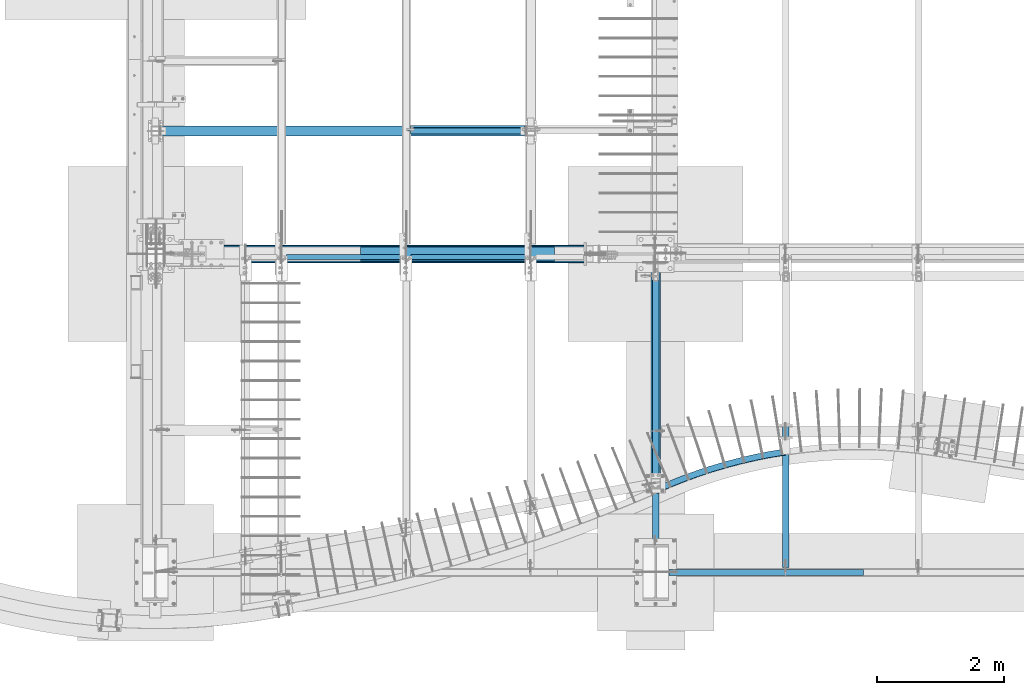
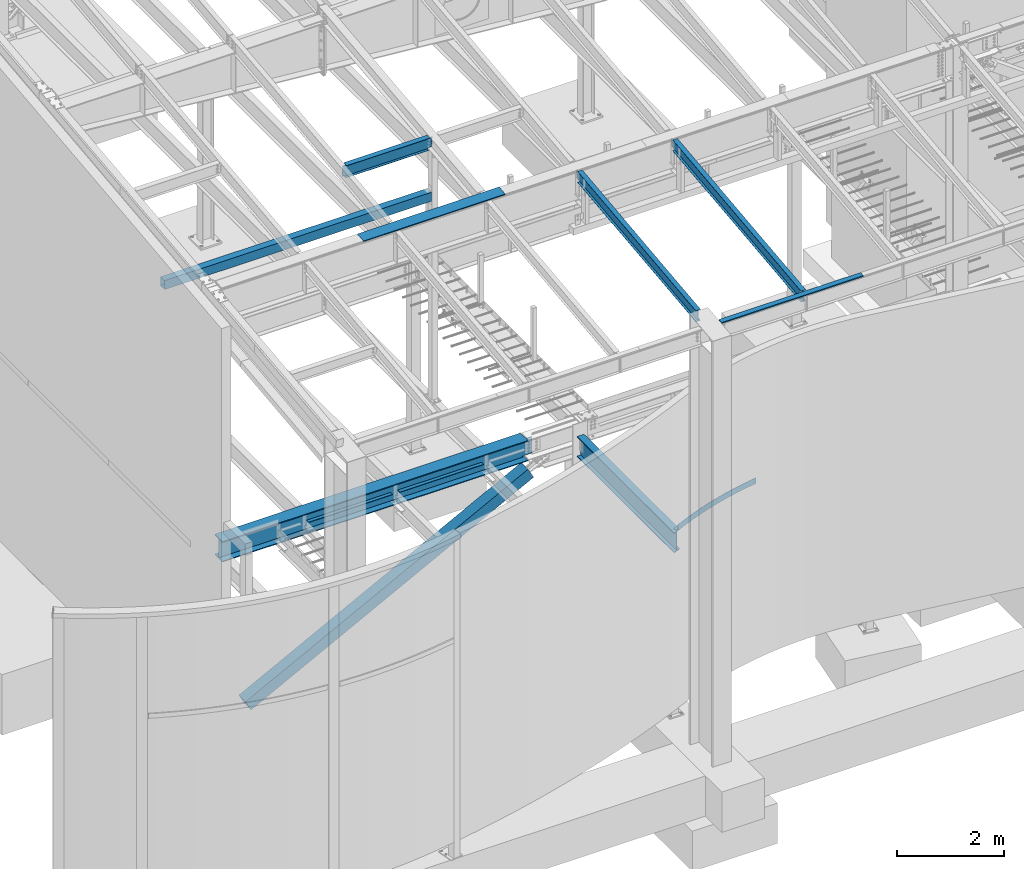
# One storey, part 705 of 1179: 11 beams, 1 member, 10 elements without a shape of their own.
"""IFC2X3 building model written with IfcOpenShell, lengths in millimetres."""

from ifc_helpers import new_model, si_unit, frame, origin_with_axes, place, context, subcontext, project, spatial, faceted_brep, material, type_object, element, aggregate, save


model = new_model("IFC2X3")

# Units and contexts
model_context = context("Model", 3, precision=1e-05, world=origin_with_axes())
body_context = subcontext(model_context, "Body", "Model", "MODEL_VIEW")
ifc_project = project(units=[si_unit("LENGTHUNIT", "METRE", prefix="MILLI"), si_unit("AREAUNIT", "SQUARE_METRE"), si_unit("VOLUMEUNIT", "CUBIC_METRE"), si_unit("MASSUNIT", "GRAM", prefix="KILO"), si_unit("TIMEUNIT", "SECOND"), si_unit("PLANEANGLEUNIT", "RADIAN"), si_unit("SOLIDANGLEUNIT", "STERADIAN"), si_unit("THERMODYNAMICTEMPERATUREUNIT", "DEGREE_CELSIUS"), si_unit("LUMINOUSINTENSITYUNIT", "LUMEN")], contexts=[model_context])

# Site, building, storey
site_placement = place(None, origin_with_axes())
site = spatial("IfcSite", under=ifc_project, at=site_placement, CompositionType="ELEMENT")
building_placement = place(site_placement, origin_with_axes())
building = spatial("IfcBuilding", under=site, at=building_placement, Name="Undefined", CompositionType="ELEMENT")
storey_placement = place(building_placement, origin_with_axes())
storey = spatial("IfcBuildingStorey", under=building, at=storey_placement, Name="Undefined", CompositionType="ELEMENT", Elevation=0.0)

# Assembly, beam
assembly_1_placement = place(storey_placement, origin_with_axes())
assembly_1 = element("IfcElementAssembly", 1, at=assembly_1_placement, inside=storey, Name="BEAM", AssemblyPlace="NOTDEFINED", PredefinedType="RIGID_FRAME")
ifc_material_1 = material(Name="STEEL/A992")
beam_type_1 = type_object("IfcBeamType", Name="W10X12", PredefinedType="NOTDEFINED")
beam_1_placement = place(assembly_1_placement, frame((10325.1, 452.231593993459, 9171.78056384809), z_axis=(-3.89779463887408e-08, -0.112282221021699, 0.993676357192035), x_axis=(0.0, 0.993676357192036, 0.112282221021699)))
beam_1 = element("IfcBeam", 2, at=beam_1_placement, type_object=beam_type_1, material=ifc_material_1, Name="BEAM", ObjectType="W10X12", context=body_context, shape_type="Brep", body=[
    faceted_brep([(4857.69134886906, 2.38125000000036, -120.649999999367), (4857.69134886908, 2.38119321150953, -125.412499999362), (4857.69133715173, 50.7999999999993, -125.412499999366), (4857.69133715173, 50.7999999999993, -120.649999999367), (4982.28709465017, 2.38125000000036, -120.649999999352), (4981.74894752234, 2.38122323349126, -125.412499999349), (48.8806597554974, -2.38124999999854, -120.649999999914), (48.8806597554974, -50.7999999999993, -120.649999999914), (4857.69136171279, -50.7999999999993, -120.649999999368), (4857.69134999544, -2.38125000000036, -120.649999999367), (76.1467808989316, 2.38124999999854, 120.649999999929), (76.1467808989316, 50.7999999999993, 120.649999999929), (4881.74500230402, 50.7999999999993, 120.650000000474), (4881.74500230402, 2.38125000000036, 120.650000000474), (48.3425126276663, -50.7999999999993, -125.412499999911), (76.1467808989316, -2.38124999999854, 120.649999999929), (76.1467808989316, -50.7999999999993, 120.649999999929), (76.6849280267622, -50.7999999999993, 125.412499999924), (76.6849280267622, 50.7999999999993, 125.412499999924), (48.8806597554974, 2.38124999999854, -120.649999999914), (48.8806597554974, 50.7999999999993, -120.649999999914), (48.3425126276663, 50.7999999999993, -125.412499999911), (4857.69136171279, -50.7999999999993, -125.412499999366), (4857.69134999547, -2.38130675233151, -125.412499999364), (4982.28709465017, -2.38125000000036, -120.649999999352), (4981.74894752234, -2.38127673034069, -125.412499999349), (4884.49824407442, -2.38125000000036, 75.1923220895023), (4880.7132366458, -2.38125000000036, 78.3905494782684), (4878.44025438672, -2.38125000000036, 82.793785937376), (4878.02533824148, -2.38125000000036, 87.7316786313622), (4881.74500230402, -2.38125000000036, 120.650000000474), (4982.37312427097, -2.38125000000036, -119.888654174249), (5002.79625141886, -2.38125000000036, 60.8521470148644), (4889.21904360274, -2.38125000000036, 73.6860048990093), (4881.74500230402, -50.7999999999993, 120.650000000474), (4882.28314943185, -50.7999999999993, 125.41250000047), (4882.28314943185, 50.7999999999993, 125.41250000047), (4878.02533824148, 2.38125000000036, 87.7316786313622), (4878.44025438672, 2.38125000000036, 82.793785937376), (4880.7132366458, 2.38125000000036, 78.3905494782684), (4884.49824407442, 2.38125000000036, 75.1923220895023), (4889.21904360274, 2.38125000000036, 73.6860048990093), (5002.79625141886, 2.38125000000036, 60.8521470148644), (4982.37311143735, 2.38125000000036, -119.888767749362)], [[[0, 1, 2, 3]], [[4, 5, 1, 0]], [[6, 7, 8, 9]], [[10, 11, 12, 13]], [[14, 7, 6, 15, 16, 17, 18, 11, 10, 19, 20, 21]], [[7, 14, 22, 8]], [[8, 22, 23, 9]], [[24, 9, 23, 25]], [[26, 27, 28, 29, 30, 15, 6, 9, 24, 31, 32, 33]], [[16, 15, 30, 34]], [[17, 16, 34, 35]], [[18, 17, 35, 36]], [[11, 18, 36, 12]], [[35, 34, 30, 29, 37, 13, 12, 36]], [[28, 38, 37, 29]], [[27, 39, 38, 28]], [[26, 40, 39, 27]], [[33, 41, 40, 26]], [[32, 42, 41, 33]], [[43, 4, 0, 19, 10, 13, 37, 38, 39, 40, 41, 42]], [[20, 19, 0, 3]], [[21, 20, 3, 2]], [[25, 23, 22, 14, 21, 2, 1, 5]], [[43, 42, 32, 31, 24, 25, 5, 4]]]),
])
aggregate(assembly_1, [beam_1])

assembly_2_placement = place(storey_placement, origin_with_axes())
assembly_2 = element("IfcElementAssembly", 3, at=assembly_2_placement, inside=storey, Name="BEAM", AssemblyPlace="NOTDEFINED", PredefinedType="RIGID_FRAME")
beam_2_placement = place(assembly_2_placement, frame((8280.4, 452.231593993459, 9171.78056384809), z_axis=(-3.89779463887408e-08, -0.112282221021699, 0.993676357192035), x_axis=(0.0, 0.993676357192036, 0.112282221021699)))
beam_2 = element("IfcBeam", 4, at=beam_2_placement, type_object=beam_type_1, material=ifc_material_1, Name="BEAM", ObjectType="W10X12", context=body_context, shape_type="Brep", body=[
    faceted_brep([(4857.69134886906, 2.38125000000036, -120.649999999367), (4857.69134886908, 2.38119321150953, -125.412499999362), (4857.69133715173, 50.7999999999993, -125.412499999366), (4857.69133715173, 50.7999999999993, -120.649999999367), (4982.28709465017, 2.38125000000036, -120.649999999352), (4981.74894752234, 2.38122323349126, -125.412499999349), (425.914889669142, -2.38124999999854, -120.64999999987), (425.914889669142, -50.7999999999993, -120.64999999987), (4857.69136171279, -50.7999999999993, -120.649999999368), (4857.69134999544, -2.38125000000036, -120.649999999367), (453.181010812576, 2.38124999999854, 120.649999999971), (453.181010812576, 50.7999999999993, 120.649999999971), (4881.74500230402, 50.7999999999993, 120.650000000474), (4881.74500230402, 2.38125000000036, 120.650000000474), (425.376742541311, -50.7999999999993, -125.412499999868), (453.181010812576, -2.38124999999854, 120.649999999971), (453.181010812576, -50.7999999999993, 120.649999999971), (453.719157940407, -50.7999999999993, 125.412499999969), (453.719157940407, 50.7999999999993, 125.412499999969), (449.277251936401, 2.38124999999854, 86.1024744511342), (431.940877010644, 2.38124999999854, -67.3211550991127), (425.914889669142, 2.38124999999854, -120.64999999987), (425.914889669142, 50.7999999999993, -120.64999999987), (425.376742541311, 50.7999999999993, -125.412499999868), (4857.69136171279, -50.7999999999993, -125.412499999366), (4857.69134999547, -2.38130675233151, -125.412499999364), (4982.28709465017, -2.38125000000036, -120.649999999352), (4981.74894752234, -2.38127673034069, -125.412499999349), (4884.49824407442, -2.38125000000036, 75.1923220895023), (4880.7132366458, -2.38125000000036, 78.3905494782684), (4878.44025438672, -2.38125000000036, 82.793785937376), (4878.02533824148, -2.38125000000036, 87.7316786313622), (4881.74500230402, -2.38125000000036, 120.650000000474), (4982.37312427097, -2.38125000000036, -119.888654174249), (5002.79625141886, -2.38125000000036, 60.8521470148644), (4889.21904360274, -2.38125000000036, 73.6860048990093), (4881.74500230402, -50.7999999999993, 120.650000000474), (4882.28314943185, -50.7999999999993, 125.41250000047), (4882.28314943185, 50.7999999999993, 125.41250000047), (4878.02533824148, 2.38125000000036, 87.7316786313622), (4878.44025438672, 2.38125000000036, 82.793785937376), (4880.7132366458, 2.38125000000036, 78.3905494782684), (4884.49824407442, 2.38125000000036, 75.1923220895023), (4889.21904360274, 2.38125000000036, 73.6860048990093), (5002.79625141886, 2.38125000000036, 60.8521470148644), (4982.37311143735, 2.38125000000036, -119.888767749362)], [[[0, 1, 2, 3]], [[4, 5, 1, 0]], [[6, 7, 8, 9]], [[10, 11, 12, 13]], [[14, 7, 6, 15, 16, 17, 18, 11, 10, 19, 20, 21, 22, 23]], [[7, 14, 24, 8]], [[8, 24, 25, 9]], [[26, 9, 25, 27]], [[28, 29, 30, 31, 32, 15, 6, 9, 26, 33, 34, 35]], [[16, 15, 32, 36]], [[17, 16, 36, 37]], [[18, 17, 37, 38]], [[11, 18, 38, 12]], [[37, 36, 32, 31, 39, 13, 12, 38]], [[30, 40, 39, 31]], [[29, 41, 40, 30]], [[28, 42, 41, 29]], [[35, 43, 42, 28]], [[34, 44, 43, 35]], [[45, 4, 0, 21, 20, 19, 10, 13, 39, 40, 41, 42, 43, 44]], [[22, 21, 0, 3]], [[23, 22, 3, 2]], [[27, 25, 24, 14, 23, 2, 1, 5]], [[45, 44, 34, 33, 26, 27, 5, 4]]]),
])
aggregate(assembly_2, [beam_2])

assembly_3_placement = place(storey_placement, origin_with_axes())
assembly_3 = element("IfcElementAssembly", 5, at=assembly_3_placement, inside=storey, Name="BEAM", AssemblyPlace="NOTDEFINED", PredefinedType="RIGID_FRAME")
beam_type_2 = type_object("IfcBeamType", Name="W12X14", PredefinedType="NOTDEFINED")
beam_3_placement = place(assembly_3_placement, frame((4368.8, 7382.95051456451, 9929.37147871498), z_axis=(0.0, -0.11280435903861, 0.993617218340085), x_axis=(1.0, 0.0, 0.0)))
beam_3 = element("IfcBeam", 6, at=beam_3_placement, type_object=beam_type_2, material=ifc_material_1, Name="BEAM", ObjectType="W12X14", context=body_context, shape_type="Brep", body=[
    faceted_brep([(15.0812499999993, -2.38124999998035, -131.762500001816), (15.0812499999993, 2.38125000001855, -131.762500001816), (53.1812501907352, 2.38125000001855, -131.762500001727), (53.1812501907352, -2.38124999998035, -131.76250000172), (58.0413297087807, 2.38125000001855, -132.729229924314), (58.0413297087807, -2.38124999997854, -132.729229924307), (62.1615061769344, 2.38125000001855, -135.482243824797), (62.1615061769344, -2.38124999997854, -135.482243824792), (64.9145200774128, 2.38125000001855, -139.602420292958), (64.9145200774128, -2.38124999997854, -139.602420292951), (65.8812500000004, 2.38125000002037, -144.462500000087), (65.8812500000004, -2.38124999997854, -144.462500000083), (65.8812500000004, -50.7999999999574, -144.462499810936), (65.8812500000004, 50.7999999999993, -144.46250000012), (65.8812500000004, 50.8000000000011, -150.812500000122), (65.8812500000004, -50.7999999999574, -150.812500000055), (1857.375, 50.7999999999593, 144.462500000054), (1857.375, 2.38124999997854, 144.462500000085), (65.8812500000004, 2.38124999997854, 144.462500000085), (65.8812500000004, 50.7999999999593, 144.462500000054), (53.1812501907352, -2.38125000001855, 131.762499998722), (53.1812501907352, 2.38124999998035, 131.762499998715), (15.0812499999993, 2.38124999998035, 131.762499998626), (15.0812499999993, -2.38125000001855, 131.762499998624), (58.0413297087807, -2.38125000001855, 132.729229921311), (58.0413297087807, 2.38124999998035, 132.729229921306), (62.1615061769344, -2.38125000001855, 135.482243821796), (62.1615061769344, 2.38124999998035, 135.482243821787), (64.9145200774128, -2.38125000001855, 139.602420289955), (64.9145200774128, 2.38124999998035, 139.60242028995), (65.8812500000004, -2.38125000001855, 144.462500000089), (1857.375, -50.7999999999993, 150.812500000124), (1857.375, 50.7999999999574, 150.812500000058), (65.8812500000004, 50.7999999999574, 150.812500000058), (65.8812500000004, -50.7999999999993, 150.812500000124), (1857.375, -50.7999999999993, 144.46250000012), (65.8812500000004, -50.7999999999993, 144.46250000012), (1857.375, -2.38125000001855, 144.462500000089), (1857.375, -2.38125000001855, 138.112499808019), (1857.375, 2.38124999998035, 138.11249980801), (1858.34172992259, -2.38125000001855, 133.252420289966), (1858.34172992259, 2.38124999998035, 133.252420289959), (1861.09474382307, -2.38125000001673, 129.132243821803), (1861.09474382307, 2.38124999998035, 129.132243821796), (1865.21492029122, -2.38125000001673, 126.379229921322), (1865.21492029122, 2.38124999998217, 126.379229921315), (1870.07499980927, -2.38125000001673, 125.412499998731), (1870.07499980927, 2.38124999998035, 125.412499998723), (1939.925, -2.38125000001673, 125.412499998822), (1939.925, 2.38124999998035, 125.412499998822), (1939.925, 2.38125000001673, -117.887500002969), (1939.925, 2.38124999998217, 112.712499998572), (1939.925, -2.38124999998035, -125.412500001634), (1939.925, 2.38125000001673, -125.412500001634), (1870.07499980927, -2.38124999998035, -125.412500001727), (1870.07499980927, 2.38125000001673, -125.412500001734), (1865.21492029122, -2.38124999998035, -126.379229924314), (1865.21492029122, 2.38125000001673, -126.379229924321), (1861.09474382307, -2.38124999998035, -129.132243824799), (1861.09474382307, 2.38125000001855, -129.132243824804), (1858.34172992259, -2.38124999998035, -133.252420292958), (1858.34172992259, 2.38125000001855, -133.252420292965), (1857.375, -2.38124999997854, -138.112499811014), (1857.375, 2.38125000001855, -138.112499811021), (1857.375, -2.38124999997854, -144.462500000083), (1857.375, -50.7999999999574, -144.462500000051), (1857.375, -50.7999999999574, -150.812500000055), (1857.375, 50.8000000000011, -150.812500000122), (1857.375, 50.7999999999993, -144.46250000012), (1857.375, 2.38125000002037, -144.462500000087), (15.0812499999993, 2.38125000001673, -117.887500002955), (15.0812499999993, 2.38124999998399, 112.712499998581)], [[[0, 1, 2, 3]], [[3, 2, 4, 5]], [[5, 4, 6, 7]], [[7, 6, 8, 9]], [[9, 8, 10, 11]], [[12, 11, 10, 13, 14, 15]], [[16, 17, 18, 19]], [[20, 21, 22, 23]], [[24, 25, 21, 20]], [[26, 27, 25, 24]], [[28, 29, 27, 26]], [[30, 18, 29, 28]], [[31, 32, 33, 34]], [[35, 31, 34, 36]], [[37, 35, 36, 30]], [[34, 33, 19, 18, 30, 36]], [[32, 16, 19, 33]], [[31, 35, 37, 38, 39, 17, 16, 32]], [[40, 41, 39, 38]], [[42, 43, 41, 40]], [[44, 45, 43, 42]], [[46, 47, 45, 44]], [[48, 49, 47, 46]], [[50, 51, 49, 48, 52, 53]], [[52, 54, 55, 53]], [[56, 57, 55, 54]], [[58, 59, 57, 56]], [[60, 61, 59, 58]], [[62, 63, 61, 60]], [[64, 65, 66, 67, 68, 69, 63, 62]], [[66, 65, 12, 15]], [[67, 66, 15, 14]], [[68, 67, 14, 13]], [[69, 68, 13, 10]], [[6, 4, 2, 1, 70, 71, 22, 21, 25, 27, 29, 18, 17, 39, 41, 43, 45, 47, 49, 51, 50, 53, 55, 57, 59, 61, 63, 69, 10, 8]], [[23, 22, 71, 70, 1, 0]], [[64, 62, 60, 58, 56, 54, 52, 48, 46, 44, 42, 40, 38, 37, 30, 28, 26, 24, 20, 23, 0, 3, 5, 7, 9, 11]], [[65, 64, 11, 12]]]),
])
aggregate(assembly_3, [beam_3])

assembly_4_placement = place(storey_placement, origin_with_axes())
assembly_4 = element("IfcElementAssembly", 7, at=assembly_4_placement, inside=storey, Name="BEAM", AssemblyPlace="NOTDEFINED", PredefinedType="RIGID_FRAME")
ifc_material_2 = material(Name="STEEL/A36")
beam_type_3 = type_object("IfcBeamType", PredefinedType="NOTDEFINED")
beam_4_placement = place(assembly_4_placement, frame((5172.07499932981, 5543.55933465712, 9826.91628422069), z_axis=(-1.0, 0.0, 0.0), x_axis=(0.0, 0.0, 1.0)))
beam_4 = element("IfcBeam", 8, at=beam_4_placement, type_object=beam_type_3, material=ifc_material_2, Name="BENT_PLATE", context=body_context, shape_type="Brep", body=[
    faceted_brep([(-2.91038304567337e-11, -4.76250000000073, -1524.0), (-2.91038304567337e-11, -4.76250000000073, 1524.0), (2.91038304567337e-11, 4.76250000000073, 1524.0), (2.91038304567337e-11, 4.76250000000073, -1524.0), (46.9151566473611, 4.76249999974698, 1524.0), (46.9151566473611, 4.76249999974698, -1524.0), (36.2535598523627, -4.76250000019536, -1524.0), (36.2535598523627, -4.76250000019536, 1524.0), (21.449529282756, -220.662499999238, 1524.0), (21.449529282756, -220.662499999238, -1524.0), (12.939957335464, -211.13749999934, -1524.0), (12.939957335464, -211.13749999934, 1524.0), (1.17463059723377e-07, -220.662499999494, 1524.0), (1.17463059723377e-07, -220.662499999494, -1524.0), (1.17350282380357e-07, -211.137499999494, 1524.0), (1.17350282380357e-07, -211.137499999494, -1524.0)], [[[0, 1, 2, 3]], [[3, 2, 4, 5]], [[1, 0, 6, 7]], [[5, 4, 8, 9]], [[7, 6, 10, 11]], [[9, 8, 12, 13]], [[8, 4, 2, 1, 7, 11, 14, 12]], [[11, 10, 15, 14]], [[10, 6, 0, 3, 5, 9, 13, 15]], [[14, 15, 13, 12]]]),
])
aggregate(assembly_4, [beam_4])

# Assembly, member
assembly_5_placement = place(storey_placement, origin_with_axes())
assembly_5 = element("IfcElementAssembly", 9, at=assembly_5_placement, inside=storey, Name="None", AssemblyPlace="NOTDEFINED", PredefinedType="RIGID_FRAME")
member_type = type_object("IfcMemberType", Name="HSS10X10X1/4", PredefinedType="NOTDEFINED")
member_placement = place(assembly_5_placement, frame((1166.68287804086, 5435.6, 166.554189613314), z_axis=(0.0, -1.0, 0.0), x_axis=(0.88706105467266, 0.0, 0.461652125829643)))
member = element("IfcMember", 10, at=member_placement, type_object=member_type, material=ifc_material_1, Name="None", ObjectType="HSS10X10X1/4", context=body_context, shape_type="Brep", body=[
    faceted_brep([(-6.09361450187862e-11, 120.650000000031, -120.650000000001), (6.00266503170133e-11, -120.650000000031, -120.650000000001), (6838.94999999862, -120.649999999846, -120.65), (6838.94999999861, 120.650000000161, -120.65), (6.00266503170133e-11, -120.650000000031, 120.650000000001), (6838.94999999862, -120.649999999846, 120.65), (-6.09361450187862e-11, 120.650000000031, 120.650000000001), (6838.94999999861, 120.650000000161, 120.65), (-6.3664629124105e-11, 127.000000000032, -127.0), (-6.3664629124105e-11, 127.000000000032, 127.0), (6838.94999999861, 127.000000000161, 127.0), (6838.94999999861, 127.000000000161, -127.0), (6.2755134422332e-11, -127.000000000033, 127.0), (6838.94999999862, -126.999999999846, 127.0), (6.2755134422332e-11, -127.000000000033, -127.0), (6838.94999999862, -126.999999999846, -127.0)], [[[0, 1, 2, 3]], [[1, 4, 5, 2]], [[4, 6, 7, 5]], [[6, 0, 3, 7]], [[8, 9, 10, 11]], [[9, 12, 13, 10]], [[12, 14, 15, 13]], [[14, 8, 11, 15]], [[13, 15, 11, 10], [5, 7, 3, 2]], [[14, 12, 9, 8], [6, 4, 1, 0]]]),
])
aggregate(assembly_5, [member])

# Assembly, beam
assembly_6_placement = place(storey_placement, origin_with_axes())
assembly_6 = element("IfcElementAssembly", 11, at=assembly_6_placement, inside=storey, Name="BEAM", AssemblyPlace="NOTDEFINED", PredefinedType="RIGID_FRAME")
beam_type_4 = type_object("IfcBeamType", PredefinedType="NOTDEFINED")
beam_5_placement = place(assembly_6_placement, frame((10017.1249999997, 485.774999119419, 9265.24531303941), z_axis=(-1.0, 0.0, 0.0), x_axis=(0.0, 0.0, 1.0)))
beam_5 = element("IfcBeam", 12, at=beam_5_placement, type_object=beam_type_4, material=ifc_material_2, Name="BENT_PLATE", context=body_context, shape_type="Brep", body=[
    faceted_brep([(0.0, -3.17499999999927, -1524.0), (6.00266503170133e-10, -3.17499999922438, 1524.00000000052), (6.00266503170133e-10, 3.17500000077416, 1524.00000000052), (0.0, 3.17499999999927, -1524.0), (36.8806648358295, 3.17499999974928, 1524.0), (36.8806648358295, 3.17499999974928, -1524.0), (29.7727112184712, -3.17500000020243, -1524.0), (29.7727112184712, -3.17500000020243, 1524.0), (25.3999996289767, -98.4249984738682, 1524.0), (25.3999996289767, -98.4249984738682, -1524.0), (19.7271291840298, -92.0749984738682, -1524.0), (19.7271291840298, -92.0749984738682, 1524.0), (2.13476596400142e-08, -98.4249984738682, 1524.0), (2.13476596400142e-08, -98.4249984738682, -1524.0), (2.13476596400142e-08, -92.0749984738682, 1524.0), (2.13476596400142e-08, -92.0749984738682, -1524.0)], [[[0, 1, 2, 3]], [[3, 2, 4, 5]], [[1, 0, 6, 7]], [[5, 4, 8, 9]], [[7, 6, 10, 11]], [[9, 8, 12, 13]], [[8, 4, 2, 1, 7, 11, 14, 12]], [[11, 10, 15, 14]], [[10, 6, 0, 3, 5, 9, 13, 15]], [[14, 15, 13, 12]]]),
])
aggregate(assembly_6, [beam_5])

# Assembly, beams
assembly_7_placement = place(storey_placement, origin_with_axes())
assembly_7 = element("IfcElementAssembly", 13, at=assembly_7_placement, inside=storey, Name="BEAM", AssemblyPlace="NOTDEFINED", PredefinedType="RIGID_FRAME")
beam_type_5 = type_object("IfcBeamType", PredefinedType="NOTDEFINED")
beam_6_placement = place(assembly_7_placement, frame((4445.0, 5391.15, 3844.131), z_axis=(0.0, 1.0, 0.0), x_axis=(1.0, 0.0, 0.0)))
beam_6 = element("IfcBeam", 14, at=beam_6_placement, type_object=beam_type_5, material=ifc_material_2, Name="PLATE", context=body_context, shape_type="Brep", body=[
    faceted_brep([(0.0, 3.96900000000005, -38.1000000000004), (0.0, 3.96900000000005, 38.1000000000004), (1803.4, 3.96900000000005, 38.1000000000004), (1803.4, 3.96900000000005, -38.1000000000004), (-3.63797880709171e-12, -3.96900000000005, 38.1000000000004), (1803.4, -3.96900000000005, 38.1000000000004), (-3.63797880709171e-12, -3.96900000000005, -38.1000000000004), (1803.4, -3.96900000000005, -38.1000000000004)], [[[0, 1, 2, 3]], [[1, 4, 5, 2]], [[4, 6, 7, 5]], [[6, 0, 3, 7]], [[5, 7, 3, 2]], [[6, 4, 1, 0]]]),
])
beam_7_placement = place(assembly_7_placement, frame((2489.2, 5391.15, 3844.131), z_axis=(0.0, 1.0, 0.0), x_axis=(1.0, 0.0, 0.0)))
beam_7 = element("IfcBeam", 15, at=beam_7_placement, type_object=beam_type_5, material=ifc_material_2, Name="PLATE", context=body_context, shape_type="Brep", body=[
    faceted_brep([(0.0, 3.96900000000005, -38.1000000000004), (0.0, 3.96900000000005, 38.1000000000004), (1803.4, 3.96900000000005, 38.1000000000004), (1803.4, 3.96900000000005, -38.1000000000004), (-3.63797880709171e-12, -3.96900000000005, 38.1000000000004), (1803.4, -3.96900000000005, 38.1000000000004), (-3.63797880709171e-12, -3.96900000000005, -38.1000000000004), (1803.4, -3.96900000000005, -38.1000000000004)], [[[0, 1, 2, 3]], [[1, 4, 5, 2]], [[4, 6, 7, 5]], [[6, 0, 3, 7]], [[5, 7, 3, 2]], [[6, 4, 1, 0]]]),
])

# Assembly, beam
assembly_8_placement = place(storey_placement, origin_with_axes())
assembly_8 = element("IfcElementAssembly", 16, at=assembly_8_placement, inside=storey, Name="BENT_PLATE", AssemblyPlace="NOTDEFINED", PredefinedType="RIGID_FRAME")
beam_type_6 = type_object("IfcBeamType", PredefinedType="NOTDEFINED")
beam_8_placement = place(assembly_8_placement, frame((10311.0905093915, 2327.25288585633, 3914.775), z_axis=(0.0, 0.0, 1.0), x_axis=(-0.976241347135425, -0.216686022030059, 0.0)))
beam_8 = element("IfcBeam", 17, at=beam_8_placement, type_object=beam_type_6, material=ifc_material_2, Name="BENT_PLATE", context=body_context, shape_type="Brep", body=[
    faceted_brep([(-7.09084831691143, -50.5522563652462, -66.6750000000002), (-7.09084831691143, -50.5522563652462, -60.3249999999998), (-0.443178031817297, 44.465483977162, -60.3249999999998), (-0.443178031817297, 44.465483977162, 66.6750000000002), (6.91215973347425e-11, 50.8000000000129, 66.6750000000002), (6.91215973347425e-11, 50.8000000000129, -66.6750000000002), (468.381702294399, -69.0111407792456, -60.3249999999998), (706.318555343563, -67.1632521933525, -60.3249999999998), (944.083390025935, -57.9304779824288, -60.3249999999998), (1181.4470556753, -41.3217164192761, -60.3249999999998), (1418.18078826021, -17.3529745336211, -60.3249999999998), (1654.05643085995, 13.9526473149756, -60.3249999999998), (1888.84665355536, 52.5649777005667, -60.3249999999998), (2122.32517252266, 98.4468032091336, -60.3249999999998), (2102.50994242848, 191.61288693229, -60.3249999999998), (1871.93293200984, 146.301248820536, -60.3249999999998), (1640.06051880417, 108.16876560544, -60.3249999999998), (1407.11617453738, 77.2521882386091, -60.3249999999998), (1173.32440403056, 53.5813131965078, -60.3249999999998), (938.910528829034, 37.1789537635007, -60.3249999999998), (704.100470044052, 28.0609180450924, -60.3249999999998), (469.12053061683, 26.2359937325405, -60.3249999999998), (234.197177214477, 31.7059396335453, -60.3249999999998), (230.502147330841, -63.4723628001266, -60.3249999999998), (234.197177214477, 31.7059396335453, 66.6750000000002), (469.12053061683, 26.2359937325405, 66.6750000000002), (704.100470044052, 28.0609180450924, 66.6750000000002), (938.910528829034, 37.1789537635007, 66.6750000000002), (1173.32440403056, 53.5813131965078, 66.6750000000002), (1407.11617453738, 77.2521882386091, 66.6750000000002), (1640.06051880417, 108.16876560544, 66.6750000000002), (1871.93293200984, 146.301248820536, 66.6750000000002), (2102.50994242848, 191.61288693229, 66.6750000000002), (2101.18892708886, 197.823959180501, 66.6750000000002), (1870.80535057347, 152.550333561868, 66.6750000000002), (1639.12745800046, 114.449840158138, 66.6750000000002), (1406.37853362252, 83.5591990900903, 66.6750000000002), (1172.78289392091, 59.9081818375587, 66.6750000000002), (938.565671415907, 43.5195825465617, 66.6750000000002), (703.95259769075, 34.4091960609881, 66.6750000000002), (469.169785838327, 32.5858026999936, 66.6750000000002), (234.443512540054, 38.0511597957907, 66.6750000000002), (234.443512540054, 38.0511597957907, -66.6750000000002), (469.169785838327, 32.5858026999936, -66.6750000000002), (703.95259769075, 34.4091960609881, -66.6750000000002), (938.565671415907, 43.5195825465617, -66.6750000000002), (1172.78289392091, 59.9081818375587, -66.6750000000002), (1406.37853362252, 83.5591990900903, -66.6750000000002), (1639.12745800046, 114.449840158138, -66.6750000000002), (1870.80535057347, 152.550333561868, -66.6750000000002), (2101.18892708886, 197.823959180501, -66.6750000000002), (2122.32517252266, 98.4468032091336, -66.6750000000002), (1888.84665355536, 52.5649777005667, -66.6750000000002), (1654.05643085995, 13.9526473149756, -66.6750000000002), (1418.18078826021, -17.3529745336211, -66.6750000000002), (1181.4470556753, -41.3217164192761, -66.6750000000002), (944.083390025935, -57.9304779824288, -66.6750000000002), (706.318555343563, -67.1632521933525, -66.6750000000002), (468.381702294399, -69.0111407792456, -66.6750000000002), (230.502147330841, -63.4723628001266, -66.6750000000002)], [[[0, 1, 2, 3, 4, 5]], [[6, 7, 8, 9, 10, 11, 12, 13, 14, 15, 16, 17, 18, 19, 20, 21, 22, 2, 1, 23]], [[3, 2, 22, 24]], [[25, 26, 27, 28, 29, 30, 31, 32, 33, 34, 35, 36, 37, 38, 39, 40, 41, 4, 3, 24]], [[5, 4, 41, 42]], [[43, 44, 45, 46, 47, 48, 49, 50, 51, 52, 53, 54, 55, 56, 57, 58, 59, 0, 5, 42]], [[1, 0, 59, 23]], [[59, 58, 6, 23]], [[41, 40, 43, 42]], [[22, 21, 25, 24]], [[58, 57, 7, 6]], [[40, 39, 44, 43]], [[21, 20, 26, 25]], [[57, 56, 8, 7]], [[39, 38, 45, 44]], [[20, 19, 27, 26]], [[56, 55, 9, 8]], [[38, 37, 46, 45]], [[19, 18, 28, 27]], [[55, 54, 10, 9]], [[37, 36, 47, 46]], [[18, 17, 29, 28]], [[54, 53, 11, 10]], [[36, 35, 48, 47]], [[17, 16, 30, 29]], [[53, 52, 12, 11]], [[35, 34, 49, 48]], [[16, 15, 31, 30]], [[32, 14, 13, 51, 50, 33]], [[52, 51, 13, 12]], [[34, 33, 50, 49]], [[15, 14, 32, 31]]]),
])
aggregate(assembly_8, [beam_8])

assembly_9_placement = place(storey_placement, origin_with_axes())
assembly_9 = element("IfcElementAssembly", 18, at=assembly_9_placement, inside=storey, Name="BEAM", AssemblyPlace="NOTDEFINED", PredefinedType="RIGID_FRAME")
ifc_material_3 = material()
beam_type_7 = type_object("IfcBeamType", Name="HSS8X6X1/4", PredefinedType="NOTDEFINED")
beam_9_placement = place(assembly_9_placement, frame((508.000000000002, 7366.0, 8750.3), z_axis=(0.0, 0.0, 1.0), x_axis=(1.0, 0.0, 0.0)))
beam_9 = element("IfcBeam", 19, at=beam_9_placement, type_object=beam_type_7, material=ifc_material_3, Name="BEAM", ObjectType="HSS8X6X1/4", context=body_context, shape_type="Brep", body=[
    faceted_brep([(4.76249999999777, 69.8500000000004, -95.25), (4.76249999999777, -69.8500000000004, -95.25), (5735.63746446261, -69.8500000000004, -95.25), (5735.63746446261, 69.8500000000004, -95.25), (4.76249999999777, -69.8500000000004, 95.25), (5735.63746446261, -69.8500000000004, 95.25), (4.76249999999777, 69.8500000000004, 95.25), (5735.63746446261, 69.8500000000004, 95.25), (4.76249999999777, 76.1999999999998, -101.6), (4.76249999999777, 76.1999999999998, 101.6), (5735.63746446261, 76.1999999999998, 101.6), (5735.63746446261, 76.1999999999998, -101.6), (4.76249999999777, -76.1999999999998, 101.6), (5735.63746446261, -76.1999999999998, 101.6), (4.76249999999777, -76.1999999999998, -101.6), (5735.63746446261, -76.1999999999998, -101.6)], [[[0, 1, 2, 3]], [[1, 4, 5, 2]], [[4, 6, 7, 5]], [[6, 0, 3, 7]], [[8, 9, 10, 11]], [[9, 12, 13, 10]], [[12, 14, 15, 13]], [[14, 8, 11, 15]], [[13, 15, 11, 10], [5, 7, 3, 2]], [[14, 12, 9, 8], [6, 4, 1, 0]]]),
])
aggregate(assembly_9, [beam_9])

assembly_10_placement = place(storey_placement, origin_with_axes())
assembly_10 = element("IfcElementAssembly", 20, at=assembly_10_placement, inside=storey, Name="BEAM", AssemblyPlace="NOTDEFINED", PredefinedType="RIGID_FRAME")
beam_type_8 = type_object("IfcBeamType", Name="W18X46", PredefinedType="NOTDEFINED")
beam_10_placement = place(assembly_10_placement, frame((8280.4, 1682.05814164811, 3619.5), z_axis=(0.0, 0.0, 1.0), x_axis=(0.0, 1.0, 0.0)))
beam_10 = element("IfcBeam", 21, at=beam_10_placement, type_object=beam_type_8, material=ifc_material_1, Name="BEAM", ObjectType="W18X46", context=body_context, shape_type="Brep", body=[
    faceted_brep([(32.4351521270223, -76.2000000000007, -212.725), (32.4351521270223, -76.2000000000007, -228.6), (3585.26685835189, -76.2000000000007, -228.6), (3585.26685835189, -76.2000000000007, -212.725), (2.05094057212636, -4.76250000000073, -212.725), (3585.26685835189, -4.76250000000073, -212.725), (2.05094057212636, -4.76250000000073, 212.725), (3585.26685835189, -4.76250000000073, 212.725), (32.4351521270223, -76.2000000000007, 212.725), (3585.26685835189, -76.2000000000007, 212.725), (32.4351521270223, -76.2000000000007, 228.6), (3585.26685835189, -76.2000000000007, 228.6), (-32.3844991900889, 76.2000000000007, 228.6), (3585.26685835189, 76.2000000000007, 228.6), (-32.3844991900889, 76.2000000000007, 212.725), (3585.26685835189, 76.2000000000007, 212.725), (-2.00028763519299, 4.76250000000073, 212.725), (3585.26685835189, 4.76250000000073, 212.725), (-2.00028763519299, 4.76250000000073, -212.725), (3585.26685835189, 4.76250000000073, -212.725), (-32.3844991900889, 76.2000000000007, -212.725), (3585.26685835189, 76.2000000000007, -212.725), (-32.3844991900889, 76.2000000000007, -228.6), (3585.26685835189, 76.2000000000007, -228.6)], [[[0, 1, 2, 3]], [[4, 0, 3, 5]], [[6, 4, 5, 7]], [[8, 6, 7, 9]], [[10, 8, 9, 11]], [[12, 10, 11, 13]], [[14, 12, 13, 15]], [[16, 14, 15, 17]], [[18, 16, 17, 19]], [[20, 18, 19, 21]], [[1, 0, 4, 6, 8, 10, 12, 14, 16, 18, 20, 22]], [[1, 22, 23, 2]], [[19, 17, 15, 13, 11, 9, 7, 5, 3, 2, 23, 21]], [[22, 20, 21, 23]]]),
])
aggregate(assembly_10, [beam_10])

# Beam
beam_type_9 = type_object("IfcBeamType", Name="W18X86", PredefinedType="NOTDEFINED")
beam_11_placement = place(assembly_7_placement, frame((431.800000000002, 5435.6, 3868.7375), z_axis=(0.0, 0.0, 1.0), x_axis=(1.0, 0.0, 0.0)))
beam_11 = element("IfcBeam", 22, at=beam_11_placement, type_object=beam_type_9, material=ifc_material_1, Name="BEAM", ObjectType="W18X86", context=body_context, shape_type="Brep", body=[
    faceted_brep([(6747.17803977433, -141.2875, 214.3125), (6747.17803977433, -6.35000000000036, 214.3125), (6747.40724900959, -6.35000000000036, 213.9155), (6747.40724900959, 6.35000000000036, 213.9155), (6747.17803977433, 6.35000000000036, 214.3125), (6747.17803977433, 141.2875, 214.3125), (6736.17946060161, 141.2875, 233.3625), (6736.17946060161, -141.2875, 233.3625), (168.275, 141.2875, -214.3125), (168.275, 6.35000000000036, -214.3125), (6736.17944459258, 6.35000000000036, -214.3125), (6736.17944459258, 141.2875, -214.3125), (6689.7386779341, -6.35000000000036, 207.055856973128), (6689.7386779341, 6.35000000000036, 207.055856973128), (6704.3150421311, 6.35000000000036, 213.9155), (6704.3150421311, -6.35000000000036, 213.9155), (6685.88292932505, -6.35000000000036, 203.741552423033), (6685.88292932505, 6.35000000000036, 203.741552423033), (6684.2815028503, -6.35000000000036, 198.915907882362), (6684.2815028503, 6.35000000000036, 198.915907882362), (6685.39070993103, -6.35000000000036, 193.953945403766), (6685.39070993103, 6.35000000000036, 193.953945403766), (6688.89449243571, -6.35000000000036, 190.269529554974), (6688.89449243571, 6.35000000000036, 190.269529554974), (6693.79448047385, -6.35000000000036, 188.9125), (6693.79448047385, 6.35000000000036, 188.9125), (6896.4030421311, -6.35000000000036, 188.9125), (6896.4030421311, 6.35000000000036, 188.9125), (6896.4030421311, -6.35000000000036, -188.9125), (6896.4030421311, 6.35000000000036, -188.9125), (6693.45048047385, -6.35000000000036, -188.9125), (6693.45048047385, 6.35000000000036, -188.9125), (6688.55049243571, -6.35000000000036, -190.269529554975), (6688.55049243571, 6.35000000000036, -190.269529554975), (6685.04670993103, -6.35000000000036, -193.953945403767), (6685.04670993103, 6.35000000000036, -193.953945403767), (6683.9375028503, -6.35000000000036, -198.915907882362), (6683.9375028503, 6.35000000000036, -198.915907882362), (6685.53892932505, -6.35000000000036, -203.741552423034), (6685.53892932505, 6.35000000000036, -203.741552423034), (6689.3946779341, -6.35000000000036, -207.055856973128), (6689.3946779341, 6.35000000000036, -207.055856973128), (6703.9710421311, -6.35000000000036, -213.9155), (6703.9710421311, 6.35000000000036, -213.9155), (6735.95024336184, -6.35000000000036, -213.9155), (6735.95024336184, 6.35000000000036, -213.9155), (168.275, -141.2875, -233.3625), (168.275, 141.2875, -233.3625), (6747.17763966962, 141.2875, -233.3625), (6747.17763966962, -141.2875, -233.3625), (168.275, -141.2875, -214.3125), (6736.17944459258, -141.2875, -214.3125), (168.275, -6.35000000000036, -214.3125), (6736.17944459258, -6.35000000000036, -214.3125), (168.275, -6.35000000000036, 214.3125), (168.275, -141.2875, 214.3125), (168.275, -141.2875, 233.3625), (168.275, 141.2875, 233.3625), (168.275, 141.2875, 214.3125), (168.275, 6.35000000000036, 214.3125)], [[[0, 1, 2, 3, 4, 5, 6, 7]], [[8, 9, 10, 11]], [[12, 13, 14, 15]], [[16, 17, 13, 12]], [[18, 19, 17, 16]], [[20, 21, 19, 18]], [[22, 23, 21, 20]], [[24, 25, 23, 22]], [[25, 24, 26, 27]], [[26, 28, 29, 27]], [[30, 31, 29, 28]], [[32, 33, 31, 30]], [[34, 35, 33, 32]], [[36, 37, 35, 34]], [[38, 39, 37, 36]], [[40, 41, 39, 38]], [[42, 43, 41, 40]], [[43, 42, 44, 45]], [[46, 47, 48, 49]], [[50, 46, 49, 51]], [[52, 50, 51, 53]], [[49, 48, 11, 10, 45, 44, 53, 51]], [[47, 8, 11, 48]], [[46, 50, 52, 54, 55, 56, 57, 58, 59, 9, 8, 47]], [[56, 55, 0, 7]], [[57, 56, 7, 6]], [[58, 57, 6, 5]], [[59, 58, 5, 4]], [[14, 13, 17, 19, 21, 23, 25, 27, 29, 31, 33, 35, 37, 39, 41, 43, 45, 10, 9, 59, 4, 3]], [[15, 14, 3, 2]], [[54, 52, 53, 44, 42, 40, 38, 36, 34, 32, 30, 28, 26, 24, 22, 20, 18, 16, 12, 15, 2, 1]], [[55, 54, 1, 0]]]),
])

aggregate(assembly_7, [beam_6, beam_7, beam_11])

save(model, "model.ifc")
